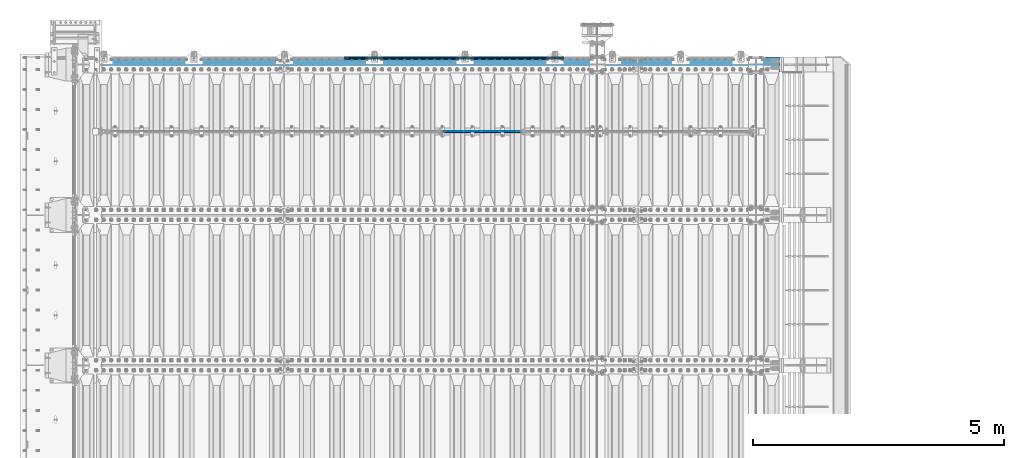
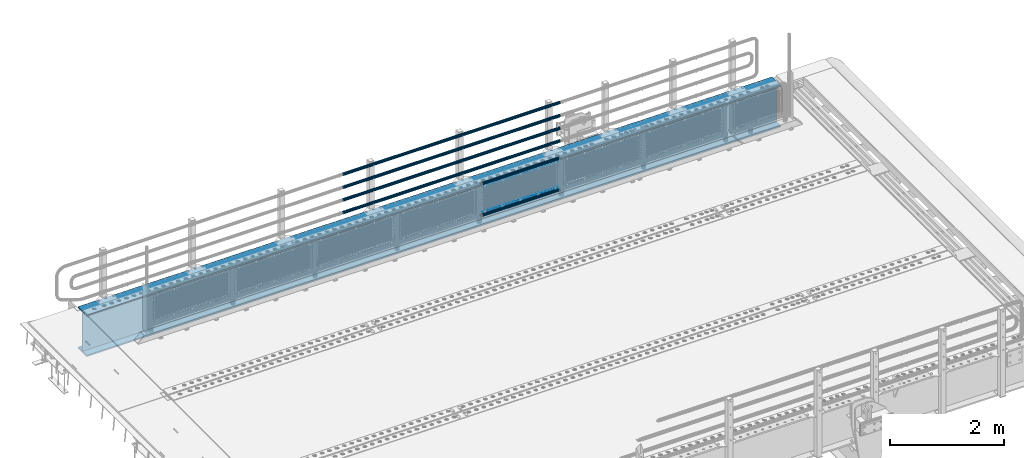
# One storey, part 114 of 219: 10 beams.
"""IFC2X3 building model written with IfcOpenShell, lengths in millimetres."""

from ifc_helpers import new_model, si_unit, frame, origin_with_axes, place, context, subcontext, project, spatial, faceted_brep, material, type_object, element, save


model = new_model("IFC2X3")

# Units and contexts
model_context = context("Model", 3, precision=1e-05, world=origin_with_axes())
body_context = subcontext(model_context, "Body", "Model", "MODEL_VIEW")
ifc_project = project(units=[si_unit("LENGTHUNIT", "METRE", prefix="MILLI"), si_unit("AREAUNIT", "SQUARE_METRE"), si_unit("VOLUMEUNIT", "CUBIC_METRE"), si_unit("MASSUNIT", "GRAM", prefix="KILO"), si_unit("TIMEUNIT", "SECOND"), si_unit("PLANEANGLEUNIT", "RADIAN"), si_unit("SOLIDANGLEUNIT", "STERADIAN"), si_unit("THERMODYNAMICTEMPERATUREUNIT", "DEGREE_CELSIUS"), si_unit("LUMINOUSINTENSITYUNIT", "LUMEN")], contexts=[model_context])

# Site, building, storey
site_placement = place(None, origin_with_axes())
site = spatial("IfcSite", under=ifc_project, at=site_placement, CompositionType="ELEMENT")
building_placement = place(site_placement, origin_with_axes())
building = spatial("IfcBuilding", under=site, at=building_placement, Name="Standard", CompositionType="ELEMENT")
storey_placement = place(building_placement, origin_with_axes())
storey = spatial("IfcBuildingStorey", under=building, at=storey_placement, Name="Undefined", CompositionType="ELEMENT", Elevation=0.0)

# Beams
ifc_material_1 = material(Name="Misc_Undefined")
beam_type_1 = type_object("IfcBeamType", Name="D3", PredefinedType="NOTDEFINED")
beam_1_placement = place(storey_placement, frame((7333.0, 31670.5, 353.020000000001), z_axis=(0.0, 0.0, 1.0), x_axis=(1.0, 0.0, 0.0)))
element("IfcBeam", 1, at=beam_1_placement, inside=storey, type_object=beam_type_1, material=ifc_material_1, ObjectType="D3", context=body_context, shape_type="Brep", body=[
    faceted_brep([(0.0, -1.5, -5.6843418860808e-14), (0.0, -0.75, -1.29903810567669), (1498.0, -0.75, -1.29903810567669), (1498.0, -1.5, 0.0), (0.0, 0.75, -1.29903810567669), (1498.0, 0.75, -1.29903810567663), (0.0, 1.5, -5.6843418860808e-14), (1498.0, 1.5, 0.0), (0.0, 0.75, 1.29903810567669), (1498.0, 0.75, 1.29903810567669), (0.0, -0.75, 1.29903810567669), (1498.0, -0.75, 1.29903810567669)], [[[0, 1, 2, 3]], [[1, 4, 5, 2]], [[4, 6, 7, 5]], [[6, 8, 9, 7]], [[8, 10, 11, 9]], [[10, 0, 3, 11]], [[5, 7, 9, 11, 3, 2]], [[10, 8, 6, 4, 1, 0]]]),
])
beam_2_placement = place(storey_placement, frame((7308.0, 31670.5, 378.020000000001), z_axis=(0.0, 0.0, 1.0), x_axis=(1.0, 0.0, 0.0)))
element("IfcBeam", 2, at=beam_2_placement, inside=storey, type_object=beam_type_1, material=ifc_material_1, ObjectType="D3", context=body_context, shape_type="Brep", body=[
    faceted_brep([(0.0, -1.5, -5.6843418860808e-14), (0.0, -0.75, -1.29903810567669), (1548.0, -0.75, -1.29903810567669), (1548.0, -1.5, 0.0), (0.0, 0.75, -1.29903810567669), (1548.0, 0.75, -1.29903810567669), (0.0, 1.5, -5.6843418860808e-14), (1548.0, 1.5, 0.0), (0.0, 0.75, 1.29903810567669), (1548.0, 0.75, 1.29903810567669), (0.0, -0.75, 1.29903810567669), (1548.0, -0.75, 1.29903810567669)], [[[0, 1, 2, 3]], [[1, 4, 5, 2]], [[4, 6, 7, 5]], [[6, 8, 9, 7]], [[8, 10, 11, 9]], [[10, 0, 3, 11]], [[5, 7, 9, 11, 3, 2]], [[10, 8, 6, 4, 1, 0]]]),
])
beam_3_placement = place(storey_placement, frame((7333.0, 31670.5, 913.020000000001), z_axis=(0.0, 0.0, 1.0), x_axis=(1.0, 0.0, 0.0)))
element("IfcBeam", 3, at=beam_3_placement, inside=storey, type_object=beam_type_1, material=ifc_material_1, ObjectType="D3", context=body_context, shape_type="Brep", body=[
    faceted_brep([(0.0, -1.5, -5.6843418860808e-14), (0.0, -0.75, -1.29903810567669), (1498.0, -0.75, -1.29903810567669), (1498.0, -1.5, 0.0), (0.0, 0.75, -1.29903810567669), (1498.0, 0.75, -1.29903810567663), (0.0, 1.5, -5.6843418860808e-14), (1498.0, 1.5, 0.0), (0.0, 0.75, 1.29903810567669), (1498.0, 0.75, 1.29903810567669), (0.0, -0.75, 1.29903810567669), (1498.0, -0.75, 1.29903810567669)], [[[0, 1, 2, 3]], [[1, 4, 5, 2]], [[4, 6, 7, 5]], [[6, 8, 9, 7]], [[8, 10, 11, 9]], [[10, 0, 3, 11]], [[5, 7, 9, 11, 3, 2]], [[10, 8, 6, 4, 1, 0]]]),
])
ifc_material_2 = material()
beam_type_2 = type_object("IfcBeamType", PredefinedType="NOTDEFINED")
beam_4_placement = place(storey_placement, frame((7287.85, 31664.5, 969.850000000001), z_axis=(0.0, 0.0, 1.0), x_axis=(1.0, 0.0, 0.0)))
element("IfcBeam", 4, at=beam_4_placement, inside=storey, type_object=beam_type_2, material=ifc_material_2, context=body_context, shape_type="Brep", body=[
    faceted_brep([(0.0, -25.3499999999985, 0.0), (0.0, -23.4203461491597, 9.70102501045585), (1588.0, -23.4203461491597, 9.70102501045506), (1588.0, -25.3499999999985, 0.0), (0.0, -17.9251569030785, 17.9251569030785), (1588.0, -17.9251569030785, 17.925156903079), (0.0, -9.70102501045403, 23.4203461491616), (1588.0, -9.70102501045403, 23.4203461491611), (0.0, 0.0, 25.3500000000004), (1588.0, 0.0, 25.35), (0.0, 9.70102501045403, 23.4203461491616), (1588.0, 9.70102501045403, 23.4203461491611), (0.0, 17.9251569030785, 17.9251569030785), (1588.0, 17.9251569030785, 17.925156903079), (0.0, 23.4203461491597, 9.70102501045585), (1588.0, 23.4203461491597, 9.70102501045506), (0.0, 25.3499999999985, 0.0), (1588.0, 25.3499999999985, 0.0), (0.0, 23.4203461491597, -9.70102501045585), (1588.0, 23.4203461491597, -9.70102501045506), (0.0, 17.9251569030785, -17.9251569030785), (1588.0, 17.9251569030785, -17.925156903079), (0.0, 9.70102501045403, -23.4203461491616), (1588.0, 9.70102501045403, -23.4203461491611), (0.0, 0.0, -25.3500000000004), (1588.0, 0.0, -25.35), (0.0, -9.70102501045403, -23.4203461491616), (1588.0, -9.70102501045403, -23.4203461491611), (0.0, -17.9251569030785, -17.9251569030785), (1588.0, -17.9251569030785, -17.925156903079), (0.0, -23.4203461491597, -9.70102501045585), (1588.0, -23.4203461491597, -9.70102501045506), (0.0, -30.1500000000015, 0.0), (0.0, -27.8549679052157, -11.5379054858076), (1588.0, -27.8549679052157, -11.5379054858075), (1588.0, -30.1500000000015, 0.0), (0.0, -21.3192694527752, -21.3192694527752), (1588.0, -21.3192694527752, -21.3192694527744), (0.0, -11.5379054858058, -27.8549679052157), (1588.0, -11.5379054858058, -27.8549679052153), (0.0, 0.0, -30.1499999999996), (1588.0, 0.0, -30.15), (0.0, 11.5379054858058, -27.8549679052157), (1588.0, 11.5379054858058, -27.8549679052153), (0.0, 21.3192694527752, -21.3192694527752), (1588.0, 21.3192694527752, -21.3192694527744), (0.0, 27.8549679052157, -11.5379054858076), (1588.0, 27.8549679052157, -11.5379054858074), (0.0, 30.1500000000015, 0.0), (1588.0, 30.1500000000015, 0.0), (0.0, 27.8549679052157, 11.5379054858076), (1588.0, 27.8549679052157, 11.5379054858074), (0.0, 21.3192694527752, 21.3192694527752), (1588.0, 21.3192694527752, 21.3192694527744), (0.0, 11.5379054858058, 27.8549679052157), (1588.0, 11.5379054858058, 27.8549679052153), (0.0, 0.0, 30.1499999999996), (1588.0, 0.0, 30.15), (0.0, -11.5379054858058, 27.8549679052157), (1588.0, -11.5379054858058, 27.8549679052153), (0.0, -21.3192694527752, 21.3192694527752), (1588.0, -21.3192694527752, 21.3192694527744), (0.0, -27.8549679052157, 11.5379054858076), (1588.0, -27.8549679052157, 11.5379054858074)], [[[0, 1, 2, 3]], [[1, 4, 5, 2]], [[4, 6, 7, 5]], [[6, 8, 9, 7]], [[8, 10, 11, 9]], [[10, 12, 13, 11]], [[12, 14, 15, 13]], [[14, 16, 17, 15]], [[16, 18, 19, 17]], [[18, 20, 21, 19]], [[20, 22, 23, 21]], [[22, 24, 25, 23]], [[24, 26, 27, 25]], [[26, 28, 29, 27]], [[28, 30, 31, 29]], [[30, 0, 3, 31]], [[32, 33, 34, 35]], [[33, 36, 37, 34]], [[36, 38, 39, 37]], [[38, 40, 41, 39]], [[40, 42, 43, 41]], [[42, 44, 45, 43]], [[44, 46, 47, 45]], [[46, 48, 49, 47]], [[48, 50, 51, 49]], [[50, 52, 53, 51]], [[52, 54, 55, 53]], [[54, 56, 57, 55]], [[56, 58, 59, 57]], [[58, 60, 61, 59]], [[60, 62, 63, 61]], [[62, 32, 35, 63]], [[37, 39, 41, 43, 45, 47, 49, 51, 53, 55, 57, 59, 61, 63, 35, 34], [5, 7, 9, 11, 13, 15, 17, 19, 21, 23, 25, 27, 29, 31, 3, 2]], [[62, 60, 58, 56, 54, 52, 50, 48, 46, 44, 42, 40, 38, 36, 33, 32], [30, 28, 26, 24, 22, 20, 18, 16, 14, 12, 10, 8, 6, 4, 1, 0]]]),
])
beam_5_placement = place(storey_placement, frame((7287.85000000001, 31664.5, 298.170000000002), z_axis=(0.0, 0.0, 1.0), x_axis=(1.0, 0.0, 0.0)))
element("IfcBeam", 5, at=beam_5_placement, inside=storey, type_object=beam_type_2, material=ifc_material_2, context=body_context, shape_type="Brep", body=[
    faceted_brep([(0.0, -25.3499999999985, 0.0), (0.0, -23.4203461491597, 9.70102501045585), (1588.0, -23.4203461491597, 9.70102501045506), (1588.0, -25.3499999999985, 0.0), (0.0, -17.9251569030785, 17.9251569030785), (1588.0, -17.9251569030785, 17.925156903079), (0.0, -9.70102501045403, 23.4203461491616), (1588.0, -9.70102501045403, 23.4203461491611), (0.0, 0.0, 25.3500000000004), (1588.0, 0.0, 25.35), (0.0, 9.70102501045403, 23.4203461491616), (1588.0, 9.70102501045403, 23.4203461491611), (0.0, 17.9251569030785, 17.9251569030785), (1588.0, 17.9251569030785, 17.925156903079), (0.0, 23.4203461491597, 9.70102501045585), (1588.0, 23.4203461491597, 9.70102501045506), (0.0, 25.3499999999985, 0.0), (1588.0, 25.3499999999985, 0.0), (0.0, 23.4203461491597, -9.70102501045585), (1588.0, 23.4203461491597, -9.70102501045506), (0.0, 17.9251569030785, -17.9251569030785), (1588.0, 17.9251569030785, -17.925156903079), (0.0, 9.70102501045403, -23.4203461491616), (1588.0, 9.70102501045403, -23.4203461491611), (0.0, 0.0, -25.3500000000004), (1588.0, 0.0, -25.35), (0.0, -9.70102501045403, -23.4203461491616), (1588.0, -9.70102501045403, -23.4203461491611), (0.0, -17.9251569030785, -17.9251569030785), (1588.0, -17.9251569030785, -17.925156903079), (0.0, -23.4203461491597, -9.70102501045585), (1588.0, -23.4203461491597, -9.70102501045506), (0.0, -30.1500000000015, 0.0), (0.0, -27.8549679052157, -11.5379054858076), (1588.0, -27.8549679052157, -11.5379054858075), (1588.0, -30.1500000000015, 0.0), (0.0, -21.3192694527752, -21.3192694527752), (1588.0, -21.3192694527752, -21.3192694527744), (0.0, -11.5379054858058, -27.8549679052157), (1588.0, -11.5379054858058, -27.8549679052153), (0.0, 0.0, -30.1499999999996), (1588.0, 0.0, -30.15), (0.0, 11.5379054858058, -27.8549679052157), (1588.0, 11.5379054858058, -27.8549679052153), (0.0, 21.3192694527752, -21.3192694527752), (1588.0, 21.3192694527752, -21.3192694527744), (0.0, 27.8549679052157, -11.5379054858076), (1588.0, 27.8549679052157, -11.5379054858074), (0.0, 30.1500000000015, 0.0), (1588.0, 30.1500000000015, 0.0), (0.0, 27.8549679052157, 11.5379054858076), (1588.0, 27.8549679052157, 11.5379054858074), (0.0, 21.3192694527752, 21.3192694527752), (1588.0, 21.3192694527752, 21.3192694527744), (0.0, 11.5379054858058, 27.8549679052157), (1588.0, 11.5379054858058, 27.8549679052153), (0.0, 0.0, 30.1499999999996), (1588.0, 0.0, 30.15), (0.0, -11.5379054858058, 27.8549679052157), (1588.0, -11.5379054858058, 27.8549679052153), (0.0, -21.3192694527752, 21.3192694527752), (1588.0, -21.3192694527752, 21.3192694527744), (0.0, -27.8549679052157, 11.5379054858076), (1588.0, -27.8549679052157, 11.5379054858074)], [[[0, 1, 2, 3]], [[1, 4, 5, 2]], [[4, 6, 7, 5]], [[6, 8, 9, 7]], [[8, 10, 11, 9]], [[10, 12, 13, 11]], [[12, 14, 15, 13]], [[14, 16, 17, 15]], [[16, 18, 19, 17]], [[18, 20, 21, 19]], [[20, 22, 23, 21]], [[22, 24, 25, 23]], [[24, 26, 27, 25]], [[26, 28, 29, 27]], [[28, 30, 31, 29]], [[30, 0, 3, 31]], [[32, 33, 34, 35]], [[33, 36, 37, 34]], [[36, 38, 39, 37]], [[38, 40, 41, 39]], [[40, 42, 43, 41]], [[42, 44, 45, 43]], [[44, 46, 47, 45]], [[46, 48, 49, 47]], [[48, 50, 51, 49]], [[50, 52, 53, 51]], [[52, 54, 55, 53]], [[54, 56, 57, 55]], [[56, 58, 59, 57]], [[58, 60, 61, 59]], [[60, 62, 63, 61]], [[62, 32, 35, 63]], [[37, 39, 41, 43, 45, 47, 49, 51, 53, 55, 57, 59, 61, 63, 35, 34], [5, 7, 9, 11, 13, 15, 17, 19, 21, 23, 25, 27, 29, 31, 3, 2]], [[62, 60, 58, 56, 54, 52, 50, 48, 46, 44, 42, 40, 38, 36, 33, 32], [30, 28, 26, 24, 22, 20, 18, 16, 14, 12, 10, 8, 6, 4, 1, 0]]]),
])
beam_type_3 = type_object("IfcBeamType", PredefinedType="NOTDEFINED")
beam_6_placement = place(storey_placement, frame((9727.99999999987, 33129.8500000001, 149.849999999748), z_axis=(0.0, 0.0, -1.0), x_axis=(-1.0, 0.0, 0.0)))
element("IfcBeam", 6, at=beam_6_placement, inside=storey, type_object=beam_type_3, material=ifc_material_2, context=body_context, shape_type="Brep", body=[
    faceted_brep([(0.0, -26.5500000000029, 0.0), (0.0, -24.5290015881765, 10.1602451292931), (4384.00249699992, -24.5290015881765, 10.1602451292931), (4384.00249699992, -26.5500000000029, 0.0), (0.0, -18.7736850405054, 18.7736850405028), (4384.00249699992, -18.7736850405054, 18.7736850405028), (0.0, -10.1602451292929, 24.5290015881747), (4384.00249699992, -10.1602451292929, 24.5290015881747), (0.0, 0.0, 26.55), (4384.00249699992, 0.0, 26.55), (0.0, 10.1602451292929, 24.5290015881747), (4384.00249699992, 10.1602451292929, 24.5290015881747), (0.0, 18.7736850405054, 18.7736850405028), (4384.00249699992, 18.7736850405054, 18.7736850405028), (0.0, 24.5290015881765, 10.1602451292931), (4384.00249699992, 24.5290015881765, 10.1602451292931), (0.0, 26.5500000000029, 0.0), (4384.00249699992, 26.5500000000029, 0.0), (0.0, 24.5290015881765, -10.1602451292931), (4384.00249699992, 24.5290015881765, -10.1602451292931), (0.0, 18.7736850405054, -18.7736850405028), (4384.00249699992, 18.7736850405054, -18.7736850405028), (0.0, 10.1602451292929, -24.5290015881747), (4384.00249699992, 10.1602451292929, -24.5290015881747), (0.0, 0.0, -26.55), (4384.00249699992, 0.0, -26.55), (0.0, -10.1602451292929, -24.5290015881747), (4384.00249699992, -10.1602451292929, -24.5290015881747), (0.0, -18.7736850405054, -18.7736850405028), (4384.00249699992, -18.7736850405054, -18.7736850405028), (0.0, -24.5290015881765, -10.1602451292931), (4384.00249699992, -24.5290015881765, -10.1602451292931), (0.0, -30.1500000000015, 0.0), (0.0, -27.8549679052157, -11.5379054858076), (4384.00249699992, -27.8549679052157, -11.5379054858075), (4384.00249699992, -30.1500000000015, 0.0), (0.0, -21.3192694527752, -21.3192694527752), (4384.00249699992, -21.3192694527752, -21.3192694527744), (0.0, -11.5379054858058, -27.8549679052157), (4384.00249699992, -11.5379054858058, -27.8549679052153), (0.0, 0.0, -30.1499999999996), (4384.00249699992, 0.0, -30.15), (0.0, 11.5379054858058, -27.8549679052157), (4384.00249699992, 11.5379054858058, -27.8549679052153), (0.0, 21.3192694527752, -21.3192694527752), (4384.00249699992, 21.3192694527752, -21.3192694527744), (0.0, 27.8549679052157, -11.5379054858076), (4384.00249699992, 27.8549679052157, -11.5379054858074), (0.0, 30.1500000000015, 0.0), (4384.00249699992, 30.1500000000015, 0.0), (0.0, 27.8549679052157, 11.5379054858076), (4384.00249699992, 27.8549679052157, 11.5379054858075), (0.0, 21.3192694527752, 21.3192694527752), (4384.00249699992, 21.3192694527752, 21.3192694527744), (0.0, 11.5379054858058, 27.8549679052157), (4384.00249699992, 11.5379054858058, 27.8549679052153), (0.0, 0.0, 30.1499999999996), (4384.00249699992, 0.0, 30.15), (0.0, -11.5379054858058, 27.8549679052157), (4384.00249699992, -11.5379054858058, 27.8549679052153), (0.0, -21.3192694527752, 21.3192694527752), (4384.00249699992, -21.3192694527752, 21.3192694527744), (0.0, -27.8549679052157, 11.5379054858076), (4384.00249699992, -27.8549679052157, 11.5379054858075)], [[[0, 1, 2, 3]], [[1, 4, 5, 2]], [[4, 6, 7, 5]], [[6, 8, 9, 7]], [[8, 10, 11, 9]], [[10, 12, 13, 11]], [[12, 14, 15, 13]], [[14, 16, 17, 15]], [[16, 18, 19, 17]], [[18, 20, 21, 19]], [[20, 22, 23, 21]], [[22, 24, 25, 23]], [[24, 26, 27, 25]], [[26, 28, 29, 27]], [[28, 30, 31, 29]], [[30, 0, 3, 31]], [[32, 33, 34, 35]], [[33, 36, 37, 34]], [[36, 38, 39, 37]], [[38, 40, 41, 39]], [[40, 42, 43, 41]], [[42, 44, 45, 43]], [[44, 46, 47, 45]], [[46, 48, 49, 47]], [[48, 50, 51, 49]], [[50, 52, 53, 51]], [[52, 54, 55, 53]], [[54, 56, 57, 55]], [[56, 58, 59, 57]], [[58, 60, 61, 59]], [[60, 62, 63, 61]], [[62, 32, 35, 63]], [[37, 39, 41, 43, 45, 47, 49, 51, 53, 55, 57, 59, 61, 63, 35, 34], [5, 7, 9, 11, 13, 15, 17, 19, 21, 23, 25, 27, 29, 31, 3, 2]], [[62, 60, 58, 56, 54, 52, 50, 48, 46, 44, 42, 40, 38, 36, 33, 32], [30, 28, 26, 24, 22, 20, 18, 16, 14, 12, 10, 8, 6, 4, 1, 0]]]),
])
beam_7_placement = place(storey_placement, frame((9727.99999999987, 33129.8500000001, 420.149999999748), z_axis=(0.0, 0.0, -1.0), x_axis=(-1.0, 0.0, 0.0)))
element("IfcBeam", 7, at=beam_7_placement, inside=storey, type_object=beam_type_3, material=ifc_material_2, context=body_context, shape_type="Brep", body=[
    faceted_brep([(0.0, -26.5500000000029, 0.0), (0.0, -24.5290015881765, 10.1602451292931), (4384.00249699992, -24.5290015881765, 10.1602451292931), (4384.00249699992, -26.5500000000029, 0.0), (0.0, -18.7736850405054, 18.7736850405028), (4384.00249699992, -18.7736850405054, 18.7736850405028), (0.0, -10.1602451292929, 24.5290015881747), (4384.00249699992, -10.1602451292929, 24.5290015881747), (0.0, 0.0, 26.55), (4384.00249699992, 0.0, 26.55), (0.0, 10.1602451292929, 24.5290015881747), (4384.00249699992, 10.1602451292929, 24.5290015881747), (0.0, 18.7736850405054, 18.7736850405028), (4384.00249699992, 18.7736850405054, 18.7736850405028), (0.0, 24.5290015881765, 10.1602451292931), (4384.00249699992, 24.5290015881765, 10.1602451292931), (0.0, 26.5500000000029, 0.0), (4384.00249699992, 26.5500000000029, 0.0), (0.0, 24.5290015881765, -10.1602451292931), (4384.00249699992, 24.5290015881765, -10.1602451292931), (0.0, 18.7736850405054, -18.7736850405028), (4384.00249699992, 18.7736850405054, -18.7736850405028), (0.0, 10.1602451292929, -24.5290015881747), (4384.00249699992, 10.1602451292929, -24.5290015881747), (0.0, 0.0, -26.55), (4384.00249699992, 0.0, -26.55), (0.0, -10.1602451292929, -24.5290015881747), (4384.00249699992, -10.1602451292929, -24.5290015881747), (0.0, -18.7736850405054, -18.7736850405028), (4384.00249699992, -18.7736850405054, -18.7736850405028), (0.0, -24.5290015881765, -10.1602451292931), (4384.00249699992, -24.5290015881765, -10.1602451292931), (0.0, -30.1500000000015, 0.0), (0.0, -27.8549679052157, -11.5379054858076), (4384.00249699992, -27.8549679052157, -11.5379054858075), (4384.00249699992, -30.1500000000015, 0.0), (0.0, -21.3192694527752, -21.3192694527752), (4384.00249699992, -21.3192694527752, -21.3192694527744), (0.0, -11.5379054858058, -27.8549679052157), (4384.00249699992, -11.5379054858058, -27.8549679052153), (0.0, 0.0, -30.1499999999996), (4384.00249699992, 0.0, -30.15), (0.0, 11.5379054858058, -27.8549679052157), (4384.00249699992, 11.5379054858058, -27.8549679052153), (0.0, 21.3192694527752, -21.3192694527752), (4384.00249699992, 21.3192694527752, -21.3192694527744), (0.0, 27.8549679052157, -11.5379054858076), (4384.00249699992, 27.8549679052157, -11.5379054858074), (0.0, 30.1500000000015, 0.0), (4384.00249699992, 30.1500000000015, 0.0), (0.0, 27.8549679052157, 11.5379054858076), (4384.00249699992, 27.8549679052157, 11.5379054858075), (0.0, 21.3192694527752, 21.3192694527752), (4384.00249699992, 21.3192694527752, 21.3192694527744), (0.0, 11.5379054858058, 27.8549679052157), (4384.00249699992, 11.5379054858058, 27.8549679052153), (0.0, 0.0, 30.1499999999996), (4384.00249699992, 0.0, 30.15), (0.0, -11.5379054858058, 27.8549679052157), (4384.00249699992, -11.5379054858058, 27.8549679052153), (0.0, -21.3192694527752, 21.3192694527752), (4384.00249699992, -21.3192694527752, 21.3192694527744), (0.0, -27.8549679052157, 11.5379054858076), (4384.00249699992, -27.8549679052157, 11.5379054858075)], [[[0, 1, 2, 3]], [[1, 4, 5, 2]], [[4, 6, 7, 5]], [[6, 8, 9, 7]], [[8, 10, 11, 9]], [[10, 12, 13, 11]], [[12, 14, 15, 13]], [[14, 16, 17, 15]], [[16, 18, 19, 17]], [[18, 20, 21, 19]], [[20, 22, 23, 21]], [[22, 24, 25, 23]], [[24, 26, 27, 25]], [[26, 28, 29, 27]], [[28, 30, 31, 29]], [[30, 0, 3, 31]], [[32, 33, 34, 35]], [[33, 36, 37, 34]], [[36, 38, 39, 37]], [[38, 40, 41, 39]], [[40, 42, 43, 41]], [[42, 44, 45, 43]], [[44, 46, 47, 45]], [[46, 48, 49, 47]], [[48, 50, 51, 49]], [[50, 52, 53, 51]], [[52, 54, 55, 53]], [[54, 56, 57, 55]], [[56, 58, 59, 57]], [[58, 60, 61, 59]], [[60, 62, 63, 61]], [[62, 32, 35, 63]], [[37, 39, 41, 43, 45, 47, 49, 51, 53, 55, 57, 59, 61, 63, 35, 34], [5, 7, 9, 11, 13, 15, 17, 19, 21, 23, 25, 27, 29, 31, 3, 2]], [[62, 60, 58, 56, 54, 52, 50, 48, 46, 44, 42, 40, 38, 36, 33, 32], [30, 28, 26, 24, 22, 20, 18, 16, 14, 12, 10, 8, 6, 4, 1, 0]]]),
])
beam_8_placement = place(storey_placement, frame((9727.99999999987, 33129.8500000001, 969.849999999748), z_axis=(0.0, 0.0, -1.0), x_axis=(-1.0, 0.0, 0.0)))
element("IfcBeam", 8, at=beam_8_placement, inside=storey, type_object=beam_type_3, material=ifc_material_2, context=body_context, shape_type="Brep", body=[
    faceted_brep([(0.0, -26.5500000000029, 0.0), (0.0, -24.5290015881765, 10.1602451292931), (4384.00249699992, -24.5290015881765, 10.1602451292931), (4384.00249699992, -26.5500000000029, 0.0), (0.0, -18.7736850405054, 18.7736850405028), (4384.00249699992, -18.7736850405054, 18.7736850405028), (0.0, -10.1602451292929, 24.5290015881747), (4384.00249699992, -10.1602451292929, 24.5290015881747), (0.0, 0.0, 26.55), (4384.00249699992, 0.0, 26.55), (0.0, 10.1602451292929, 24.5290015881747), (4384.00249699992, 10.1602451292929, 24.5290015881747), (0.0, 18.7736850405054, 18.7736850405028), (4384.00249699992, 18.7736850405054, 18.7736850405028), (0.0, 24.5290015881765, 10.1602451292931), (4384.00249699992, 24.5290015881765, 10.1602451292931), (0.0, 26.5500000000029, 0.0), (4384.00249699992, 26.5500000000029, 0.0), (0.0, 24.5290015881765, -10.1602451292931), (4384.00249699992, 24.5290015881765, -10.1602451292931), (0.0, 18.7736850405054, -18.7736850405028), (4384.00249699992, 18.7736850405054, -18.7736850405028), (0.0, 10.1602451292929, -24.5290015881747), (4384.00249699992, 10.1602451292929, -24.5290015881747), (0.0, 0.0, -26.55), (4384.00249699992, 0.0, -26.55), (0.0, -10.1602451292929, -24.5290015881747), (4384.00249699992, -10.1602451292929, -24.5290015881747), (0.0, -18.7736850405054, -18.7736850405028), (4384.00249699992, -18.7736850405054, -18.7736850405028), (0.0, -24.5290015881765, -10.1602451292931), (4384.00249699992, -24.5290015881765, -10.1602451292931), (0.0, -30.1500000000015, 0.0), (0.0, -27.8549679052157, -11.5379054858076), (4384.00249699992, -27.8549679052157, -11.5379054858075), (4384.00249699992, -30.1500000000015, 0.0), (0.0, -21.3192694527752, -21.3192694527752), (4384.00249699992, -21.3192694527752, -21.3192694527744), (0.0, -11.5379054858058, -27.8549679052157), (4384.00249699992, -11.5379054858058, -27.8549679052153), (0.0, 0.0, -30.1499999999996), (4384.00249699992, 0.0, -30.15), (0.0, 11.5379054858058, -27.8549679052157), (4384.00249699992, 11.5379054858058, -27.8549679052153), (0.0, 21.3192694527752, -21.3192694527752), (4384.00249699992, 21.3192694527752, -21.3192694527744), (0.0, 27.8549679052157, -11.5379054858076), (4384.00249699992, 27.8549679052157, -11.5379054858074), (0.0, 30.1500000000015, 0.0), (4384.00249699992, 30.1500000000015, 0.0), (0.0, 27.8549679052157, 11.5379054858076), (4384.00249699992, 27.8549679052157, 11.5379054858075), (0.0, 21.3192694527752, 21.3192694527752), (4384.00249699992, 21.3192694527752, 21.3192694527744), (0.0, 11.5379054858058, 27.8549679052157), (4384.00249699992, 11.5379054858058, 27.8549679052153), (0.0, 0.0, 30.1499999999996), (4384.00249699992, 0.0, 30.15), (0.0, -11.5379054858058, 27.8549679052157), (4384.00249699992, -11.5379054858058, 27.8549679052153), (0.0, -21.3192694527752, 21.3192694527752), (4384.00249699992, -21.3192694527752, 21.3192694527744), (0.0, -27.8549679052157, 11.5379054858076), (4384.00249699992, -27.8549679052157, 11.5379054858075)], [[[0, 1, 2, 3]], [[1, 4, 5, 2]], [[4, 6, 7, 5]], [[6, 8, 9, 7]], [[8, 10, 11, 9]], [[10, 12, 13, 11]], [[12, 14, 15, 13]], [[14, 16, 17, 15]], [[16, 18, 19, 17]], [[18, 20, 21, 19]], [[20, 22, 23, 21]], [[22, 24, 25, 23]], [[24, 26, 27, 25]], [[26, 28, 29, 27]], [[28, 30, 31, 29]], [[30, 0, 3, 31]], [[32, 33, 34, 35]], [[33, 36, 37, 34]], [[36, 38, 39, 37]], [[38, 40, 41, 39]], [[40, 42, 43, 41]], [[42, 44, 45, 43]], [[44, 46, 47, 45]], [[46, 48, 49, 47]], [[48, 50, 51, 49]], [[50, 52, 53, 51]], [[52, 54, 55, 53]], [[54, 56, 57, 55]], [[56, 58, 59, 57]], [[58, 60, 61, 59]], [[60, 62, 63, 61]], [[62, 32, 35, 63]], [[37, 39, 41, 43, 45, 47, 49, 51, 53, 55, 57, 59, 61, 63, 35, 34], [5, 7, 9, 11, 13, 15, 17, 19, 21, 23, 25, 27, 29, 31, 3, 2]], [[62, 60, 58, 56, 54, 52, 50, 48, 46, 44, 42, 40, 38, 36, 33, 32], [30, 28, 26, 24, 22, 20, 18, 16, 14, 12, 10, 8, 6, 4, 1, 0]]]),
])
beam_9_placement = place(storey_placement, frame((9727.99999999987, 33129.8500000001, 689.849999999748), z_axis=(0.0, 0.0, -1.0), x_axis=(-1.0, 0.0, 0.0)))
element("IfcBeam", 9, at=beam_9_placement, inside=storey, type_object=beam_type_3, material=ifc_material_2, context=body_context, shape_type="Brep", body=[
    faceted_brep([(0.0, -26.5500000000029, 0.0), (0.0, -24.5290015881765, 10.1602451292931), (4384.00249699992, -24.5290015881765, 10.1602451292931), (4384.00249699992, -26.5500000000029, 0.0), (0.0, -18.7736850405054, 18.7736850405028), (4384.00249699992, -18.7736850405054, 18.7736850405028), (0.0, -10.1602451292929, 24.5290015881747), (4384.00249699992, -10.1602451292929, 24.5290015881747), (0.0, 0.0, 26.55), (4384.00249699992, 0.0, 26.55), (0.0, 10.1602451292929, 24.5290015881747), (4384.00249699992, 10.1602451292929, 24.5290015881747), (0.0, 18.7736850405054, 18.7736850405028), (4384.00249699992, 18.7736850405054, 18.7736850405028), (0.0, 24.5290015881765, 10.1602451292931), (4384.00249699992, 24.5290015881765, 10.1602451292931), (0.0, 26.5500000000029, 0.0), (4384.00249699992, 26.5500000000029, 0.0), (0.0, 24.5290015881765, -10.1602451292931), (4384.00249699992, 24.5290015881765, -10.1602451292931), (0.0, 18.7736850405054, -18.7736850405028), (4384.00249699992, 18.7736850405054, -18.7736850405028), (0.0, 10.1602451292929, -24.5290015881747), (4384.00249699992, 10.1602451292929, -24.5290015881747), (0.0, 0.0, -26.55), (4384.00249699992, 0.0, -26.55), (0.0, -10.1602451292929, -24.5290015881747), (4384.00249699992, -10.1602451292929, -24.5290015881747), (0.0, -18.7736850405054, -18.7736850405028), (4384.00249699992, -18.7736850405054, -18.7736850405028), (0.0, -24.5290015881765, -10.1602451292931), (4384.00249699992, -24.5290015881765, -10.1602451292931), (0.0, -30.1500000000015, 0.0), (0.0, -27.8549679052157, -11.5379054858076), (4384.00249699992, -27.8549679052157, -11.5379054858075), (4384.00249699992, -30.1500000000015, 0.0), (0.0, -21.3192694527752, -21.3192694527752), (4384.00249699992, -21.3192694527752, -21.3192694527744), (0.0, -11.5379054858058, -27.8549679052157), (4384.00249699992, -11.5379054858058, -27.8549679052153), (0.0, 0.0, -30.1499999999996), (4384.00249699992, 0.0, -30.15), (0.0, 11.5379054858058, -27.8549679052157), (4384.00249699992, 11.5379054858058, -27.8549679052153), (0.0, 21.3192694527752, -21.3192694527752), (4384.00249699992, 21.3192694527752, -21.3192694527744), (0.0, 27.8549679052157, -11.5379054858076), (4384.00249699992, 27.8549679052157, -11.5379054858074), (0.0, 30.1500000000015, 0.0), (4384.00249699992, 30.1500000000015, 0.0), (0.0, 27.8549679052157, 11.5379054858076), (4384.00249699992, 27.8549679052157, 11.5379054858075), (0.0, 21.3192694527752, 21.3192694527752), (4384.00249699992, 21.3192694527752, 21.3192694527744), (0.0, 11.5379054858058, 27.8549679052157), (4384.00249699992, 11.5379054858058, 27.8549679052153), (0.0, 0.0, 30.1499999999996), (4384.00249699992, 0.0, 30.15), (0.0, -11.5379054858058, 27.8549679052157), (4384.00249699992, -11.5379054858058, 27.8549679052153), (0.0, -21.3192694527752, 21.3192694527752), (4384.00249699992, -21.3192694527752, 21.3192694527744), (0.0, -27.8549679052157, 11.5379054858076), (4384.00249699992, -27.8549679052157, 11.5379054858075)], [[[0, 1, 2, 3]], [[1, 4, 5, 2]], [[4, 6, 7, 5]], [[6, 8, 9, 7]], [[8, 10, 11, 9]], [[10, 12, 13, 11]], [[12, 14, 15, 13]], [[14, 16, 17, 15]], [[16, 18, 19, 17]], [[18, 20, 21, 19]], [[20, 22, 23, 21]], [[22, 24, 25, 23]], [[24, 26, 27, 25]], [[26, 28, 29, 27]], [[28, 30, 31, 29]], [[30, 0, 3, 31]], [[32, 33, 34, 35]], [[33, 36, 37, 34]], [[36, 38, 39, 37]], [[38, 40, 41, 39]], [[40, 42, 43, 41]], [[42, 44, 45, 43]], [[44, 46, 47, 45]], [[46, 48, 49, 47]], [[48, 50, 51, 49]], [[50, 52, 53, 51]], [[52, 54, 55, 53]], [[54, 56, 57, 55]], [[56, 58, 59, 57]], [[58, 60, 61, 59]], [[60, 62, 63, 61]], [[62, 32, 35, 63]], [[37, 39, 41, 43, 45, 47, 49, 51, 53, 55, 57, 59, 61, 63, 35, 34], [5, 7, 9, 11, 13, 15, 17, 19, 21, 23, 25, 27, 29, 31, 3, 2]], [[62, 60, 58, 56, 54, 52, 50, 48, 46, 44, 42, 40, 38, 36, 33, 32], [30, 28, 26, 24, 22, 20, 18, 16, 14, 12, 10, 8, 6, 4, 1, 0]]]),
])
ifc_material_3 = material(Name="STEEL/S355N")
beam_type_4 = type_object("IfcBeamType", Name="HEA900", PredefinedType="NOTDEFINED")
beam_10_placement = place(storey_placement, frame((10.0, 33000.0, -445.0), z_axis=(0.0, 0.0, 1.0), x_axis=(1.0, 0.0, 0.0)))
element("IfcBeam", 10, at=beam_10_placement, inside=storey, type_object=beam_type_4, material=ifc_material_3, ObjectType="HEA900", context=body_context, shape_type="Brep", body=[
    faceted_brep([(0.0, 150.0, -445.0), (0.0, 150.0, -415.0), (14017.0, 150.0, -415.0), (14017.0, 150.0, -445.0), (0.0, 8.0, -415.0), (14017.0, 8.0, -415.0), (0.0, 8.0, 415.0), (14017.0, 8.0, 415.0), (0.0, 150.0, 415.0), (14017.0, 150.0, 415.0), (0.0, 150.0, 445.0), (14017.0, 150.0, 445.0), (0.0, -150.0, 445.0), (14017.0, -150.0, 445.0), (0.0, -150.0, 415.0), (14017.0, -150.0, 415.0), (0.0, -8.0, 415.0), (14017.0, -8.0, 415.0), (0.0, -8.0, -415.0), (14017.0, -8.0, -415.0), (0.0, -150.0, -415.0), (14017.0, -150.0, -415.0), (0.0, -150.0, -445.0), (14017.0, -150.0, -445.0)], [[[0, 1, 2, 3]], [[1, 4, 5, 2]], [[4, 6, 7, 5]], [[6, 8, 9, 7]], [[8, 10, 11, 9]], [[10, 12, 13, 11]], [[12, 14, 15, 13]], [[14, 16, 17, 15]], [[16, 18, 19, 17]], [[18, 20, 21, 19]], [[20, 22, 23, 21]], [[22, 0, 3, 23]], [[5, 7, 9, 11, 13, 15, 17, 19, 21, 23, 3, 2]], [[22, 20, 18, 16, 14, 12, 10, 8, 6, 4, 1, 0]]]),
])

save(model, "model.ifc")
